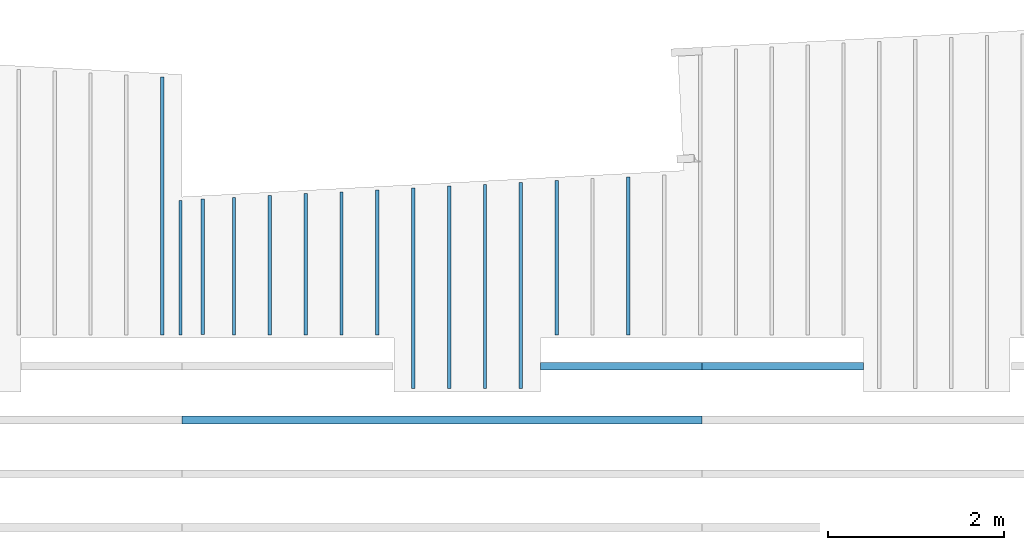
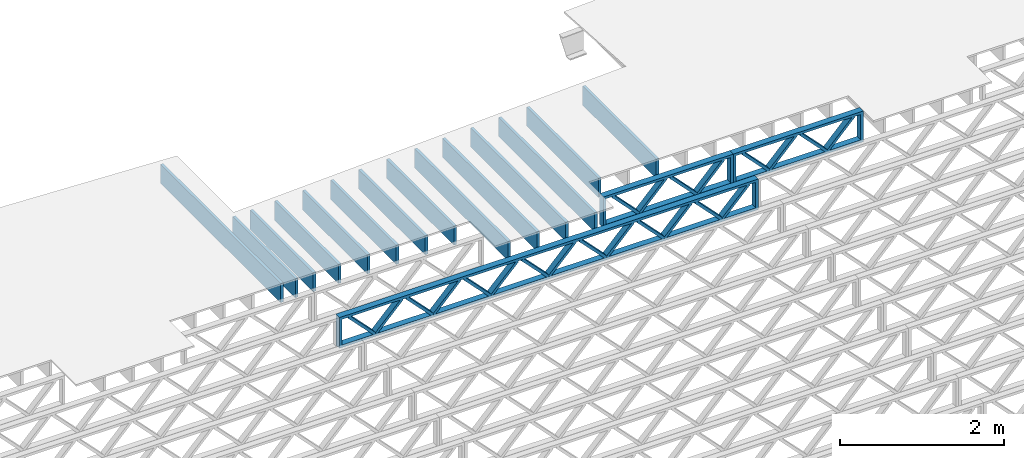
# One storey, part 5 of 13: 17 beams, 3 elements without a shape of their own.
"""IFC4 building model written with IfcOpenShell, lengths in feet."""

import ifcopenshell
import ifcopenshell.guid

model = None  # the IFC model being written
_history = None  # IfcOwnerHistory: only IFC2X3 demands one
_inside = {}  # id of a spatial element -> (the spatial element, [elements in it])
_under = {}  # id of a project, library or spatial element -> (it, [spatial elements below it])
_declared = {}  # id of a project -> (the project, [libraries it declares])
_typed = {}  # id of a type object -> (the type object, [elements of that type])
_made_of = {}  # id of a material, layer set ... -> (it, [elements and type objects made of it])


def new_model(schema):
    """Start an empty IFC model of exactly this schema.

    Asked for "IFC4X3", IfcOpenShell would pick the latest addendum, in which some entities
    have other attributes; the version numbers below select the first issue.
    IFC2X3 requires an IfcOwnerHistory on every rooted entity: one is made here for all.
    """
    global model, _history
    if schema == "IFC4X3":
        model = ifcopenshell.file(schema_version=(4, 3, 0, 0))
    else:
        model = ifcopenshell.file(schema=schema)
    _inside.clear()
    _under.clear()
    _declared.clear()
    _typed.clear()
    _made_of.clear()
    _history = None
    if model.schema == "IFC2X3":
        org = make("IfcOrganization", Name="unknown")
        user = make(
            "IfcPersonAndOrganization",
            ThePerson=make("IfcPerson", FamilyName="unknown"),
            TheOrganization=org,
        )
        app = make(
            "IfcApplication",
            ApplicationDeveloper=org,
            Version="unknown",
            ApplicationFullName="unknown",
            ApplicationIdentifier="unknown",
        )
        _history = make(
            "IfcOwnerHistory",
            OwningUser=user,
            OwningApplication=app,
            ChangeAction="ADDED",
            CreationDate=0,
        )
    return model


def make(cls, **values):
    """One entity of the class cls with the attributes given. An attribute that is None is left unset."""
    return model.create_entity(
        cls, **{name: value for name, value in values.items() if value is not None}
    )


def entity(cls, *values):
    """Any entity or typed value of the class cls, its attributes in the order of the schema. None: left unset."""
    e = model.create_entity(cls)
    for i, value in enumerate(values):
        if value is not None:
            e[i] = value
    return e


def rooted(cls, **values):
    """An entity with a GlobalId (a new one), such as an element, a storey or a relation."""
    return make(cls, GlobalId=ifcopenshell.guid.new(), OwnerHistory=_history, **values)


def si_unit(unit_type, name, prefix=None):
    """IfcSIUnit, for example si_unit("LENGTHUNIT", "METRE", prefix="MILLI")."""
    return make("IfcSIUnit", UnitType=unit_type, Prefix=prefix, Name=name)


def converted_unit(unit_type, name, factor, base, dimensions=None, offset=None):
    """IfcConversionBasedUnit, such as the inch: factor (a typed value) times the base unit."""
    return make(
        "IfcConversionBasedUnit"
        if offset is None
        else "IfcConversionBasedUnitWithOffset",
        ConversionOffset=offset,
        Dimensions=None
        if dimensions is None
        else entity("IfcDimensionalExponents", *dimensions),
        UnitType=unit_type,
        Name=name,
        ConversionFactor=make(
            "IfcMeasureWithUnit", ValueComponent=factor, UnitComponent=base
        ),
    )


def derived_unit(unit_type, elements):
    """IfcDerivedUnit: a product of units, each with its exponent."""
    return make(
        "IfcDerivedUnit",
        Elements=[
            make("IfcDerivedUnitElement", Unit=unit, Exponent=power)
            for unit, power in elements
        ],
        UnitType=unit_type,
    )


def assignment(units):
    """IfcUnitAssignment: the units of a project."""
    return None if units is None else make("IfcUnitAssignment", Units=units)


def point(xyz):
    """IfcCartesianPoint."""
    return None if xyz is None else make("IfcCartesianPoint", Coordinates=xyz)


def direction(xyz):
    """IfcDirection."""
    return None if xyz is None else make("IfcDirection", DirectionRatios=xyz)


def frame(location, z_axis=None, x_axis=None):
    """IfcAxis2Placement3D, a coordinate frame: its origin and axes. An axis left out is left unset."""
    return make(
        "IfcAxis2Placement3D",
        Location=point(location),
        Axis=direction(z_axis),
        RefDirection=direction(x_axis),
    )


def frame_2d(location, x_axis=None):
    """IfcAxis2Placement2D, a coordinate frame in the plane: its origin and x axis."""
    return make(
        "IfcAxis2Placement2D", Location=point(location), RefDirection=direction(x_axis)
    )


def origin():
    """The frame at (0, 0, 0) with its axes left unset."""
    return frame((0.0, 0.0, 0.0))


def origin_2d_with_axis():
    """The frame at (0, 0) in the plane with the x axis (1, 0) written out."""
    return frame_2d((0.0, 0.0), x_axis=(1.0, 0.0))


def place(relative_to, where):
    """IfcLocalPlacement: puts the frame where relative to a parent placement (None: the world)."""
    return make(
        "IfcLocalPlacement", PlacementRelTo=relative_to, RelativePlacement=where
    )


def context(
    kind, dimensions, precision=None, world=None, true_north=None, identifier=None
):
    """IfcGeometricRepresentationContext, for example the 3D "Model" context."""
    return make(
        "IfcGeometricRepresentationContext",
        ContextIdentifier=identifier,
        ContextType=kind,
        CoordinateSpaceDimension=dimensions,
        Precision=precision,
        WorldCoordinateSystem=world,
        TrueNorth=true_north,
    )


def subcontext(parent, identifier, kind, view, scale=None):
    """IfcGeometricRepresentationSubContext, for example "Body" below "Model"."""
    return make(
        "IfcGeometricRepresentationSubContext",
        ContextIdentifier=identifier,
        ContextType=kind,
        ParentContext=parent,
        TargetScale=scale,
        TargetView=view,
    )


def project(units=None, contexts=None):
    """IfcProject with its units and contexts."""
    return rooted(
        "IfcProject",
        Name="project",
        RepresentationContexts=contexts,
        UnitsInContext=assignment(units),
    )


def spatial(cls, under=None, at=None, **own):
    """A site, building, storey or space (cls), placed at a placement, below another one or the project."""
    s = rooted(cls, ObjectPlacement=at, **own)
    if under is not None:
        _under.setdefault(under.id(), (under, []))[1].append(s)
    return s


def profile(cls, at=None, kind="AREA", **sizes):
    """A parametric profile (cls). Its sizes go by their IFC names, for example OverallWidth=200.0."""
    return make(cls, ProfileType=kind, Position=at, **sizes)


def rectangle(**sizes):
    """IfcRectangleProfileDef."""
    return profile("IfcRectangleProfileDef", **sizes)


def extrude(swept, where, along, depth):
    """IfcExtrudedAreaSolid: the profile swept, set in the frame where, extruded along a direction by depth."""
    return make(
        "IfcExtrudedAreaSolid",
        SweptArea=swept,
        Position=where,
        ExtrudedDirection=direction(along),
        Depth=depth,
    )


def shape(context_of_items, identifier, shape_type, items):
    """IfcShapeRepresentation: the items that make up one representation, for example the "Body"."""
    return make(
        "IfcShapeRepresentation",
        ContextOfItems=context_of_items,
        RepresentationIdentifier=identifier,
        RepresentationType=shape_type,
        Items=items,
    )


def source(mapping_origin, context_of_items, identifier, shape_type, items):
    """IfcRepresentationMap: a shape defined once, which mapped items show again and again."""
    return make(
        "IfcRepresentationMap",
        MappingOrigin=mapping_origin,
        MappedRepresentation=shape(context_of_items, identifier, shape_type, items),
    )


def transform(
    local_origin,
    x_axis=None,
    y_axis=None,
    z_axis=None,
    scale=None,
    scale2=None,
    scale3=None,
    uniform=True,
):
    """IfcCartesianTransformationOperator3D, or its non-uniform kind. x_axis, y_axis, z_axis: its Axis1, 2, 3."""
    if uniform:
        return make(
            "IfcCartesianTransformationOperator3D",
            Axis1=direction(x_axis),
            Axis2=direction(y_axis),
            LocalOrigin=point(local_origin),
            Scale=scale,
            Axis3=direction(z_axis),
        )
    return make(
        "IfcCartesianTransformationOperator3DnonUniform",
        Axis1=direction(x_axis),
        Axis2=direction(y_axis),
        LocalOrigin=point(local_origin),
        Scale=scale,
        Axis3=direction(z_axis),
        Scale2=scale2,
        Scale3=scale3,
    )


def mapped(mapping_source, mapping_target):
    """IfcMappedItem: shows the shape of a source again, moved by a transform."""
    return make(
        "IfcMappedItem", MappingSource=mapping_source, MappingTarget=mapping_target
    )


def material(Name=None, Category=None):
    """IfcMaterial."""
    return make("IfcMaterial", Name=Name, Category=Category)


def material_profile(
    of_material, cross_section, Name=None, Category=None, Priority=None
):
    """IfcMaterialProfile: a cross section and its material."""
    return make(
        "IfcMaterialProfile",
        Name=Name,
        Material=of_material,
        Profile=cross_section,
        Priority=Priority,
        Category=Category,
    )


def profile_set(profiles, Name=None, composite=None):
    """IfcMaterialProfileSet."""
    return make(
        "IfcMaterialProfileSet",
        Name=Name,
        MaterialProfiles=profiles,
        CompositeProfile=composite,
    )


def profile_usage(for_profile_set, cardinal=None, extent=None):
    """IfcMaterialProfileSetUsage: how a profile set lies along its element."""
    return make(
        "IfcMaterialProfileSetUsage",
        ForProfileSet=for_profile_set,
        CardinalPoint=cardinal,
        ReferenceExtent=extent,
    )


def made_of(thing, what):
    """Note that an element or type object is made of a material, layer set ...; save() writes the relation."""
    if what is not None:
        _made_of.setdefault(what.id(), (what, []))[1].append(thing)
    return thing


def type_object(cls, material=None, **own):
    """A type object (cls), such as IfcWallType, which elements share."""
    return made_of(rooted(cls, **own), material)


def type_shapes(of_type, sources):
    """Give a type object the sources (RepresentationMaps) that its elements show as mapped items."""
    of_type.RepresentationMaps = sources


def element(
    cls,
    number,
    at=None,
    inside=None,
    cuts=None,
    type_object=None,
    material=None,
    context=None,
    identifier="Body",
    shape_type=None,
    held_by="IfcProductDefinitionShape",
    body=None,
    shapes=None,
    **own,
):
    """One element of the class cls, such as IfcWall. Its Tag is "e" and its number.

    at: its placement. inside: the storey or other place that contains it. cuts: it is an
    opening in that element (IfcRelVoidsElement). A single representation is given by context,
    identifier, shape_type and body (its items); several are given by shapes. held_by: the class
    of the entity that holds the representations. save() writes the other relations.
    """
    e = rooted(cls, Tag="e%d" % number, ObjectPlacement=at, **own)
    if body is not None:
        shapes = [shape(context, identifier, shape_type, body)]
    if shapes is not None:
        e.Representation = make(held_by, Representations=shapes)
    if inside is not None:
        _inside.setdefault(inside.id(), (inside, []))[1].append(e)
    if cuts is not None:
        rooted(
            "IfcRelVoidsElement", RelatingBuildingElement=cuts, RelatedOpeningElement=e
        )
    if type_object is not None:
        _typed.setdefault(type_object.id(), (type_object, []))[1].append(e)
    return made_of(e, material)


def aggregate(whole, parts):
    """IfcRelAggregates: a whole, such as a stair, and the parts it consists of."""
    return rooted("IfcRelAggregates", RelatingObject=whole, RelatedObjects=parts)


def save(model, path):
    """Write the relations noted so far, then the file.

    IfcRelAggregates (storeys below a building ...), IfcRelContainedInSpatialStructure (elements
    in a storey), IfcRelDefinesByType, IfcRelAssociatesMaterial and IfcRelDeclares: one each for
    every whole, place, type object, material and project.
    """
    for whole, parts in _under.values():
        aggregate(whole, parts)
    for where, things in _inside.values():
        rooted(
            "IfcRelContainedInSpatialStructure",
            RelatedElements=things,
            RelatingStructure=where,
        )
    for kind, things in _typed.values():
        rooted("IfcRelDefinesByType", RelatedObjects=things, RelatingType=kind)
    for what, things in _made_of.values():
        rooted("IfcRelAssociatesMaterial", RelatedObjects=things, RelatingMaterial=what)
    for by, libraries in _declared.values():
        rooted("IfcRelDeclares", RelatingContext=by, RelatedDefinitions=libraries)
    model.write(path)


model = new_model("IFC4")

# Units and contexts
model_context_1 = context("Model", 3, precision=0.0001, world=origin(), true_north=direction((6.12303176911189e-17, 1.0)))
model_context_2 = context("Model", 3, precision=0.0001, world=origin(), true_north=direction((6.12303176911189e-17, 1.0)))
body_context = subcontext(model_context_2, "Body", "Model", "MODEL_VIEW")
ifc_project = project(units=[converted_unit("LENGTHUNIT", "FOOT", entity("IfcRatioMeasure", 0.3048), si_unit("LENGTHUNIT", "METRE"), dimensions=[1, 0, 0, 0, 0, 0, 0]), converted_unit("AREAUNIT", "SQUARE FOOT", entity("IfcRatioMeasure", 0.09290304), si_unit("AREAUNIT", "SQUARE_METRE"), dimensions=[2, 0, 0, 0, 0, 0, 0]), converted_unit("VOLUMEUNIT", "CUBIC FOOT", entity("IfcRatioMeasure", 0.028316846592), si_unit("VOLUMEUNIT", "CUBIC_METRE"), dimensions=[3, 0, 0, 0, 0, 0, 0]), converted_unit("PLANEANGLEUNIT", "DEGREE", entity("IfcRatioMeasure", 0.0174532925199433), si_unit("PLANEANGLEUNIT", "RADIAN"), dimensions=[0, 0, 0, 0, 0, 0, 0]), si_unit("MASSUNIT", "GRAM", prefix="KILO"), derived_unit("MASSDENSITYUNIT", [(si_unit("MASSUNIT", "GRAM", prefix="KILO"), 1), (si_unit("LENGTHUNIT", "METRE"), -3)]), derived_unit("MOMENTOFINERTIAUNIT", [(si_unit("LENGTHUNIT", "METRE"), 4)]), si_unit("TIMEUNIT", "SECOND"), si_unit("FREQUENCYUNIT", "HERTZ"), si_unit("THERMODYNAMICTEMPERATUREUNIT", "DEGREE_CELSIUS"), derived_unit("THERMALTRANSMITTANCEUNIT", [(si_unit("MASSUNIT", "GRAM", prefix="KILO"), 1), (si_unit("THERMODYNAMICTEMPERATUREUNIT", "KELVIN"), -1), (si_unit("TIMEUNIT", "SECOND"), -3)]), derived_unit("VOLUMETRICFLOWRATEUNIT", [(si_unit("LENGTHUNIT", "METRE"), 3), (si_unit("TIMEUNIT", "SECOND"), -1)]), si_unit("ELECTRICCURRENTUNIT", "AMPERE"), si_unit("ELECTRICVOLTAGEUNIT", "VOLT"), si_unit("POWERUNIT", "WATT"), si_unit("FORCEUNIT", "NEWTON"), si_unit("ILLUMINANCEUNIT", "LUX"), si_unit("LUMINOUSFLUXUNIT", "LUMEN"), si_unit("LUMINOUSINTENSITYUNIT", "CANDELA"), derived_unit("USERDEFINED", [(si_unit("MASSUNIT", "GRAM", prefix="KILO"), -1), (si_unit("LENGTHUNIT", "METRE"), -2), (si_unit("TIMEUNIT", "SECOND"), 3), (si_unit("LUMINOUSFLUXUNIT", "LUMEN"), 1)]), derived_unit("LINEARVELOCITYUNIT", [(si_unit("LENGTHUNIT", "METRE"), 1), (si_unit("TIMEUNIT", "SECOND"), -1)]), si_unit("PRESSUREUNIT", "PASCAL"), derived_unit("USERDEFINED", [(si_unit("LENGTHUNIT", "METRE"), -2), (si_unit("MASSUNIT", "GRAM", prefix="KILO"), 1), (si_unit("TIMEUNIT", "SECOND"), -2)]), derived_unit("LINEARFORCEUNIT", [(si_unit("MASSUNIT", "GRAM", prefix="KILO"), 1), (si_unit("LENGTHUNIT", "METRE"), 1), (si_unit("TIMEUNIT", "SECOND"), -2), (si_unit("LENGTHUNIT", "METRE"), -1)]), derived_unit("PLANARFORCEUNIT", [(si_unit("MASSUNIT", "GRAM", prefix="KILO"), 1), (si_unit("LENGTHUNIT", "METRE"), 1), (si_unit("TIMEUNIT", "SECOND"), -2), (si_unit("LENGTHUNIT", "METRE"), -2)])], contexts=[model_context_1])

# Site, building, storey
site_placement = place(None, origin())
site = spatial("IfcSite", under=ifc_project, at=site_placement, CompositionType="ELEMENT")
building_placement = place(site_placement, origin())
building = spatial("IfcBuilding", under=site, at=building_placement, CompositionType="ELEMENT")
storey_placement = place(building_placement, frame((0.0, 0.0, 21.46875)))
storey = spatial("IfcBuildingStorey", under=building, at=storey_placement, Name="3RD FLOOR", CompositionType="ELEMENT", Elevation=21.46875)

# Assembly, beam
assembly_1_placement = place(storey_placement, origin())
assembly_1 = element("IfcElementAssembly", 1, at=assembly_1_placement, inside=storey, Name="Structural Beam System:Structural Framing System", ObjectType="Structural Beam System:Structural Framing System", AssemblyPlace="NOTDEFINED", PredefinedType="BEAM_GRID")
ifc_material_1 = material(Name="WOOD TRUSS", Category="Materials")
ifc_material_profile_1 = material_profile(ifc_material_1, rectangle(XDim=1.73473973950632, YDim=0.125, at=frame_2d((-1.11022302462516e-16, 8.32667268468867e-17), x_axis=(1.0, 0.0))))
ifc_material_profile_2 = material_profile(ifc_material_1, rectangle(XDim=1.73473973950633, YDim=0.125, at=frame_2d((-1.11022302462516e-16, 8.32667268468867e-17), x_axis=(1.0, 0.0))))
ifc_material_profile_3 = material_profile(ifc_material_1, rectangle(XDim=1.73473973950632, YDim=0.125, at=frame_2d((-5.55111512312578e-17, 1.38777878078145e-16), x_axis=(1.0, 0.0))))
ifc_material_profile_4 = material_profile(ifc_material_1, rectangle(XDim=1.73473973950633, YDim=0.125, at=frame_2d((-1.11022302462516e-16, 8.32667268468867e-17), x_axis=(1.0, 0.0))))
ifc_material_profile_5 = material_profile(ifc_material_1, rectangle(XDim=1.73473973950632, YDim=0.125, at=frame_2d((-1.11022302462516e-16, 8.32667268468867e-17), x_axis=(1.0, 0.0))))
ifc_material_profile_6 = material_profile(ifc_material_1, rectangle(XDim=1.73473973950633, YDim=0.125, at=frame_2d((-2.77555756156289e-16, 3.05311331771918e-16), x_axis=(1.0, 0.0))))
ifc_material_profile_7 = material_profile(ifc_material_1, rectangle(XDim=1.73473973950632, YDim=0.124999999999999, at=frame_2d((-3.88578058618805e-16, -2.4980018054066e-16), x_axis=(1.0, 0.0))))
ifc_material_profile_8 = material_profile(ifc_material_1, rectangle(XDim=1.73473973950633, YDim=0.125, at=frame_2d((2.77555756156289e-16, -3.05311331771918e-16), x_axis=(1.0, 0.0))))
ifc_material_profile_9 = material_profile(ifc_material_1, rectangle(XDim=1.73473973950632, YDim=0.124999999999999, at=frame_2d((-1.11022302462516e-16, 8.32667268468867e-17), x_axis=(1.0, 0.0))))
ifc_material_profile_10 = material_profile(ifc_material_1, rectangle(XDim=1.73473973950633, YDim=0.125, at=origin_2d_with_axis()))
ifc_material_profile_11 = material_profile(ifc_material_1, rectangle(XDim=0.124999999999982, YDim=0.291666666666668, at=origin_2d_with_axis()))
ifc_material_profile_12 = material_profile(ifc_material_1, rectangle(XDim=0.124999999999932, YDim=0.291666666666664, at=origin_2d_with_axis()))
ifc_material_profile_13 = material_profile(ifc_material_1, rectangle(XDim=1.25000000000002, YDim=0.29166666666667, at=origin_2d_with_axis()))
ifc_material_profile_14 = material_profile(ifc_material_1, rectangle(XDim=1.25000000000004, YDim=0.291666666666667, at=origin_2d_with_axis()))
ifc_profile_set_1 = profile_set([ifc_material_profile_1, ifc_material_profile_2, ifc_material_profile_3, ifc_material_profile_4, ifc_material_profile_5, ifc_material_profile_6, ifc_material_profile_7, ifc_material_profile_8, ifc_material_profile_9, ifc_material_profile_10, ifc_material_profile_11, ifc_material_profile_12, ifc_material_profile_13, ifc_material_profile_14])
ifc_profile_usage_1 = profile_usage(ifc_profile_set_1, cardinal=8)
beam_type_1 = type_object("IfcBeamType", PredefinedType="BEAM", material=ifc_profile_set_1)
shared_shape_1 = source(origin(), body_context, "Body", "SweptSolid", [
    extrude(rectangle(XDim=1.73473973950632, YDim=0.125, at=frame_2d((0.0, 1.66533453693773e-16), x_axis=(1.0, 0.0))), frame((1.95847610985504, -0.145833333333334, 0.0), z_axis=(0.0, 1.0, 0.0), x_axis=(0.693383046997606, 0.0, 0.720569184836762)), (0.0, 0.0, 1.0), 0.291666666666667),
    extrude(rectangle(XDim=1.73473973950633, YDim=0.125, at=frame_2d((-5.55111512312578e-17, 8.32667268468867e-17), x_axis=(1.0, 0.0))), frame((0.708190236181772, -0.145833333333334, 0.0), z_axis=(0.0, 1.0, 0.0), x_axis=(0.69338304699761, 0.0, -0.720569184836758)), (0.0, 0.0, 1.0), 0.291666666666667),
    extrude(rectangle(XDim=1.73473973950632, YDim=0.125, at=frame_2d((0.0, 1.66533453693773e-16), x_axis=(1.0, 0.0))), frame((-0.708190236181118, -0.145833333333334, 0.0), z_axis=(0.0, 1.0, 0.0), x_axis=(0.693383046997606, 0.0, 0.720569184836762)), (0.0, 0.0, 1.0), 0.291666666666667),
    extrude(rectangle(XDim=1.73473973950633, YDim=0.125, at=frame_2d((-2.22044604925031e-16, 2.22044604925031e-16), x_axis=(1.0, 0.0))), frame((-1.95847610985439, -0.145833333333334, 0.0), z_axis=(0.0, 1.0, 0.0), x_axis=(0.69338304699761, 0.0, -0.720569184836758)), (0.0, 0.0, 1.0), 0.291666666666666),
    extrude(rectangle(XDim=0.124999999999982, YDim=0.291666666666668, at=origin_2d_with_axis()), frame((-2.99999983968466, 0.0, 0.687500000000054), z_axis=(1.0, 0.0, 0.0), x_axis=(0.0, 0.0, -1.0)), (0.0, 0.0, 1.0), 5.99999967936932),
    extrude(rectangle(XDim=0.124999999999932, YDim=0.291666666666664, at=origin_2d_with_axis()), frame((-2.99999983968445, 0.0, -0.687499999999984), z_axis=(1.0, 0.0, 0.0), x_axis=(0.0, 0.0, -1.0)), (0.0, 0.0, 1.0), 5.99999967936911),
    extrude(rectangle(XDim=1.25000000000002, YDim=0.29166666666667, at=origin_2d_with_axis()), frame((2.87499983968464, 0.0, 0.0), z_axis=(1.0, 0.0, 0.0), x_axis=(0.0, 0.0, -1.0)), (0.0, 0.0, 1.0), 0.12500000000002),
    extrude(rectangle(XDim=1.25000000000004, YDim=0.291666666666667, at=origin_2d_with_axis()), frame((-2.99999983968466, 0.0, 0.0), z_axis=(1.0, 0.0, 0.0), x_axis=(0.0, 0.0, -1.0)), (0.0, 0.0, 1.0), 0.125000000000023),
])
type_shapes(beam_type_1, [shared_shape_1])
beam_1_placement = place(assembly_1_placement, frame((-219.404827312476, 957.861934882651, -0.947916666666874), z_axis=(0.0, 0.0, 1.0), x_axis=(-1.0, 0.0, 0.0)))
beam_1 = element("IfcBeam", 2, at=beam_1_placement, type_object=beam_type_1, material=ifc_profile_usage_1, PredefinedType="BEAM", context=body_context, shape_type="MappedRepresentation", body=[
    mapped(shared_shape_1, transform((0.0, 0.0, 0.0), scale=1.0)),
])
aggregate(assembly_1, [beam_1])

# Beam
ifc_material_2 = material(Category="Materials")
ifc_material_profile_15 = material_profile(ifc_material_2, rectangle(XDim=0.9375, YDim=0.125000000000011, at=origin_2d_with_axis()))
ifc_profile_set_2 = profile_set([ifc_material_profile_15])
ifc_profile_usage_2 = profile_usage(ifc_profile_set_2, cardinal=8)
beam_type_2 = type_object("IfcBeamType", PredefinedType="BEAM", material=ifc_profile_set_2)
shared_shape_2 = source(origin(), body_context, "Body", "SweptSolid", [
    extrude(rectangle(XDim=0.9375, YDim=0.125000000000011, at=origin_2d_with_axis()), frame((-2.50173504911743, 0.0, 0.0), z_axis=(1.0, 0.0, 0.0), x_axis=(0.0, 0.0, -1.0)), (0.0, 0.0, 1.0), 5.00347009823486),
])
type_shapes(beam_type_2, [shared_shape_2])
beam_2_placement = place(storey_placement, frame((-241.800660485556, 961.531253902547, -0.729166666666714), z_axis=(0.0, 0.0, 1.0), x_axis=(0.0, 1.0, 0.0)))
element("IfcBeam", 3, at=beam_2_placement, inside=storey, type_object=beam_type_2, material=ifc_profile_usage_2, PredefinedType="BEAM", context=body_context, shape_type="MappedRepresentation", body=[
    mapped(shared_shape_2, transform((0.0, 0.0, 0.0), scale=1.0)),
])

# Assembly, beams
assembly_2_placement = place(storey_placement, origin())
assembly_2 = element("IfcElementAssembly", 4, at=assembly_2_placement, inside=storey, Name="Structural Beam System:Structural Framing System", ObjectType="Structural Beam System:Structural Framing System", AssemblyPlace="NOTDEFINED", PredefinedType="BEAM_GRID")
ifc_profile_usage_3 = profile_usage(ifc_profile_set_2, cardinal=8)
beam_type_3 = type_object("IfcBeamType", PredefinedType="BEAM", material=ifc_profile_set_2)
shared_shape_3 = source(origin(), body_context, "Body", "SweptSolid", [
    extrude(rectangle(XDim=0.9375, YDim=0.125000000000011, at=origin_2d_with_axis()), frame((-2.93819683267299, 0.0, 0.0), z_axis=(1.0, 0.0, 0.0), x_axis=(0.0, 0.0, -1.0)), (0.0, 0.0, 1.0), 5.87639366534597),
])
type_shapes(beam_type_3, [shared_shape_3])
beam_3_placement = place(assembly_2_placement, frame((-225.144289395965, 961.967715694021, -0.729166666666714), z_axis=(0.0, 0.0, 1.0), x_axis=(0.0, 1.0, 0.0)))
beam_3 = element("IfcBeam", 5, at=beam_3_placement, type_object=beam_type_3, material=ifc_profile_usage_3, PredefinedType="BEAM", context=body_context, shape_type="MappedRepresentation", body=[
    mapped(shared_shape_3, transform((0.0, 0.0, 0.0), scale=1.0)),
])
ifc_profile_usage_4 = profile_usage(ifc_profile_set_2, cardinal=8)
beam_type_4 = type_object("IfcBeamType", PredefinedType="BEAM", material=ifc_profile_set_2)
shared_shape_4 = source(origin(), body_context, "Body", "SweptSolid", [
    extrude(rectangle(XDim=0.9375, YDim=0.125000000000011, at=origin_2d_with_axis()), frame((-3.83338259433134, 0.0, 0.0), z_axis=(1.0, 0.0, 0.0), x_axis=(0.0, 0.0, -1.0)), (0.0, 0.0, 1.0), 7.66676518866268),
])
type_shapes(beam_type_4, [shared_shape_4])
beam_4_placement = place(assembly_2_placement, frame((-229.144289395965, 960.862898815231, -0.729166666666714), z_axis=(0.0, 0.0, 1.0), x_axis=(0.0, 1.0, 0.0)))
beam_4 = element("IfcBeam", 6, at=beam_4_placement, type_object=beam_type_4, material=ifc_profile_usage_4, PredefinedType="BEAM", context=body_context, shape_type="MappedRepresentation", body=[
    mapped(shared_shape_4, transform((0.0, 0.0, 0.0), scale=1.0)),
])
ifc_profile_usage_5 = profile_usage(ifc_profile_set_2, cardinal=8)
beam_type_5 = type_object("IfcBeamType", PredefinedType="BEAM", material=ifc_profile_set_2)
shared_shape_5 = source(origin(), body_context, "Body", "SweptSolid", [
    extrude(rectangle(XDim=0.9375, YDim=0.125000000000011, at=origin_2d_with_axis()), frame((-3.79844407480942, 0.0, 0.0), z_axis=(1.0, 0.0, 0.0), x_axis=(0.0, 0.0, -1.0)), (0.0, 0.0, 1.0), 7.59688814961885),
])
type_shapes(beam_type_5, [shared_shape_5])
beam_5_placement = place(assembly_2_placement, frame((-230.477622729298, 960.827960295709, -0.729166666666714), z_axis=(0.0, 0.0, 1.0), x_axis=(0.0, 1.0, 0.0)))
beam_5 = element("IfcBeam", 7, at=beam_5_placement, type_object=beam_type_5, material=ifc_profile_usage_5, PredefinedType="BEAM", context=body_context, shape_type="MappedRepresentation", body=[
    mapped(shared_shape_5, transform((0.0, 0.0, 0.0), scale=1.0)),
])
ifc_profile_usage_6 = profile_usage(ifc_profile_set_2, cardinal=8)
beam_type_6 = type_object("IfcBeamType", PredefinedType="BEAM", material=ifc_profile_set_2)
shared_shape_6 = source(origin(), body_context, "Body", "SweptSolid", [
    extrude(rectangle(XDim=0.9375, YDim=0.125000000000011, at=origin_2d_with_axis()), frame((-2.65868951796261, 0.0, 0.0), z_axis=(1.0, 0.0, 0.0), x_axis=(0.0, 0.0, -1.0)), (0.0, 0.0, 1.0), 5.31737903592523),
])
type_shapes(beam_type_6, [shared_shape_6])
beam_6_placement = place(assembly_2_placement, frame((-235.810956062631, 961.68820669638, -0.729166666666714), z_axis=(0.0, 0.0, 1.0), x_axis=(0.0, 1.0, 0.0)))
beam_6 = element("IfcBeam", 8, at=beam_6_placement, type_object=beam_type_6, material=ifc_profile_usage_6, PredefinedType="BEAM", context=body_context, shape_type="MappedRepresentation", body=[
    mapped(shared_shape_6, transform((0.0, 0.0, 0.0), scale=1.0)),
])
ifc_profile_usage_7 = profile_usage(ifc_profile_set_2, cardinal=8)
beam_type_7 = type_object("IfcBeamType", PredefinedType="BEAM", material=ifc_profile_set_2)
shared_shape_7 = source(origin(), body_context, "Body", "SweptSolid", [
    extrude(rectangle(XDim=0.9375, YDim=0.125000000000011, at=origin_2d_with_axis()), frame((-2.62375083093946, 0.0, 0.0), z_axis=(1.0, 0.0, 0.0), x_axis=(0.0, 0.0, -1.0)), (0.0, 0.0, 1.0), 5.24750166187891),
])
type_shapes(beam_type_7, [shared_shape_7])
beam_7_placement = place(assembly_2_placement, frame((-237.144289395965, 961.653268344359, -0.729166666666714), z_axis=(0.0, 0.0, 1.0), x_axis=(0.0, 1.0, 0.0)))
beam_7 = element("IfcBeam", 9, at=beam_7_placement, type_object=beam_type_7, material=ifc_profile_usage_7, PredefinedType="BEAM", context=body_context, shape_type="MappedRepresentation", body=[
    mapped(shared_shape_7, transform((0.0, 0.0, 0.0), scale=1.0)),
])
ifc_profile_usage_8 = profile_usage(ifc_profile_set_2, cardinal=8)
beam_type_8 = type_object("IfcBeamType", PredefinedType="BEAM", material=ifc_profile_set_2)
shared_shape_8 = source(origin(), body_context, "Body", "SweptSolid", [
    extrude(rectangle(XDim=0.9375, YDim=0.125000000000011, at=origin_2d_with_axis()), frame((-4.79624042361354, 0.0, 0.0), z_axis=(1.0, 0.0, 0.0), x_axis=(0.0, 0.0, -1.0)), (0.0, 0.0, 1.0), 9.59248084722708),
])
type_shapes(beam_type_8, [shared_shape_8])
beam_8_placement = place(assembly_2_placement, frame((-242.477622729298, 963.825759277043, -0.729166666666714), z_axis=(0.0, 0.0, 1.0), x_axis=(0.0, 1.0, 0.0)))
beam_8 = element("IfcBeam", 10, at=beam_8_placement, type_object=beam_type_8, material=ifc_profile_usage_8, PredefinedType="BEAM", context=body_context, shape_type="MappedRepresentation", body=[
    mapped(shared_shape_8, transform((0.0, 0.0, 0.0), scale=1.0)),
])
ifc_profile_usage_9 = profile_usage(ifc_profile_set_2, cardinal=8)
beam_type_9 = type_object("IfcBeamType", PredefinedType="BEAM", material=ifc_profile_set_2)
shared_shape_9 = source(origin(), body_context, "Body", "SweptSolid", [
    extrude(rectangle(XDim=0.9375, YDim=0.125000000000011, at=origin_2d_with_axis()), frame((-2.55387345689314, 0.0, 0.0), z_axis=(1.0, 0.0, 0.0), x_axis=(0.0, 0.0, -1.0)), (0.0, 0.0, 1.0), 5.10774691378629),
])
type_shapes(beam_type_9, [shared_shape_9])
beam_9_placement = place(assembly_2_placement, frame((-239.810956062631, 961.583391640318, -0.729166666666714), z_axis=(0.0, 0.0, 1.0), x_axis=(0.0, 1.0, 0.0)))
beam_9 = element("IfcBeam", 11, at=beam_9_placement, type_object=beam_type_9, material=ifc_profile_usage_9, PredefinedType="BEAM", context=body_context, shape_type="MappedRepresentation", body=[
    mapped(shared_shape_9, transform((0.0, 0.0, 0.0), scale=1.0)),
])
ifc_profile_usage_10 = profile_usage(ifc_profile_set_2, cardinal=8)
beam_type_10 = type_object("IfcBeamType", PredefinedType="BEAM", material=ifc_profile_set_2)
shared_shape_10 = source(origin(), body_context, "Body", "SweptSolid", [
    extrude(rectangle(XDim=0.9375, YDim=0.125000000000011, at=origin_2d_with_axis()), frame((-2.58881214391624, 0.0, 0.0), z_axis=(1.0, 0.0, 0.0), x_axis=(0.0, 0.0, -1.0)), (0.0, 0.0, 1.0), 5.17762428783249),
])
type_shapes(beam_type_10, [shared_shape_10])
beam_10_placement = place(assembly_2_placement, frame((-238.477622729298, 961.618329992338, -0.729166666666714), z_axis=(0.0, 0.0, 1.0), x_axis=(0.0, 1.0, 0.0)))
beam_10 = element("IfcBeam", 12, at=beam_10_placement, type_object=beam_type_10, material=ifc_profile_usage_10, PredefinedType="BEAM", context=body_context, shape_type="MappedRepresentation", body=[
    mapped(shared_shape_10, transform((0.0, 0.0, 0.0), scale=1.0)),
])
ifc_profile_usage_11 = profile_usage(ifc_profile_set_2, cardinal=8)
beam_type_11 = type_object("IfcBeamType", PredefinedType="BEAM", material=ifc_profile_set_2)
shared_shape_11 = source(origin(), body_context, "Body", "SweptSolid", [
    extrude(rectangle(XDim=0.9375, YDim=0.125000000000011, at=origin_2d_with_axis()), frame((-2.69362820498583, 0.0, 0.0), z_axis=(1.0, 0.0, 0.0), x_axis=(0.0, 0.0, -1.0)), (0.0, 0.0, 1.0), 5.38725640997166),
])
type_shapes(beam_type_11, [shared_shape_11])
beam_11_placement = place(assembly_2_placement, frame((-234.477622729298, 961.723145048401, -0.729166666666714), z_axis=(0.0, 0.0, 1.0), x_axis=(0.0, 1.0, 0.0)))
beam_11 = element("IfcBeam", 13, at=beam_11_placement, type_object=beam_type_11, material=ifc_profile_usage_11, PredefinedType="BEAM", context=body_context, shape_type="MappedRepresentation", body=[
    mapped(shared_shape_11, transform((0.0, 0.0, 0.0), scale=1.0)),
])
ifc_profile_usage_12 = profile_usage(ifc_profile_set_2, cardinal=8)
beam_type_12 = type_object("IfcBeamType", PredefinedType="BEAM", material=ifc_profile_set_2)
shared_shape_12 = source(origin(), body_context, "Body", "SweptSolid", [
    extrude(rectangle(XDim=0.9375, YDim=0.125000000000011, at=origin_2d_with_axis()), frame((-3.72856703576554, 0.0, 0.0), z_axis=(1.0, 0.0, 0.0), x_axis=(0.0, 0.0, -1.0)), (0.0, 0.0, 1.0), 7.45713407153107),
])
type_shapes(beam_type_12, [shared_shape_12])
beam_12_placement = place(assembly_2_placement, frame((-233.144289395965, 960.758083256665, -0.729166666666714), z_axis=(0.0, 0.0, 1.0), x_axis=(0.0, 1.0, 0.0)))
beam_12 = element("IfcBeam", 14, at=beam_12_placement, type_object=beam_type_12, material=ifc_profile_usage_12, PredefinedType="BEAM", context=body_context, shape_type="MappedRepresentation", body=[
    mapped(shared_shape_12, transform((0.0, 0.0, 0.0), scale=1.0)),
])
ifc_profile_usage_13 = profile_usage(ifc_profile_set_2, cardinal=8)
beam_type_13 = type_object("IfcBeamType", PredefinedType="BEAM", material=ifc_profile_set_2)
shared_shape_13 = source(origin(), body_context, "Body", "SweptSolid", [
    extrude(rectangle(XDim=0.9375, YDim=0.125000000000011, at=origin_2d_with_axis()), frame((-3.76350555528745, 0.0, 0.0), z_axis=(1.0, 0.0, 0.0), x_axis=(0.0, 0.0, -1.0)), (0.0, 0.0, 1.0), 7.5270111105749),
])
type_shapes(beam_type_13, [shared_shape_13])
beam_13_placement = place(assembly_2_placement, frame((-231.810956062631, 960.793021776187, -0.729166666666714), z_axis=(0.0, 0.0, 1.0), x_axis=(0.0, 1.0, 0.0)))
beam_13 = element("IfcBeam", 15, at=beam_13_placement, type_object=beam_type_13, material=ifc_profile_usage_13, PredefinedType="BEAM", context=body_context, shape_type="MappedRepresentation", body=[
    mapped(shared_shape_13, transform((0.0, 0.0, 0.0), scale=1.0)),
])
ifc_profile_usage_14 = profile_usage(ifc_profile_set_2, cardinal=8)
beam_type_14 = type_object("IfcBeamType", PredefinedType="BEAM", material=ifc_profile_set_2)
shared_shape_14 = source(origin(), body_context, "Body", "SweptSolid", [
    extrude(rectangle(XDim=0.9375, YDim=0.125000000000011, at=origin_2d_with_axis()), frame((-2.86831945862667, 0.0, 0.0), z_axis=(1.0, 0.0, 0.0), x_axis=(0.0, 0.0, -1.0)), (0.0, 0.0, 1.0), 5.73663891725334),
])
type_shapes(beam_type_14, [shared_shape_14])
beam_14_placement = place(assembly_2_placement, frame((-227.810956062631, 961.897838989979, -0.729166666666714), z_axis=(0.0, 0.0, 1.0), x_axis=(0.0, 1.0, 0.0)))
beam_14 = element("IfcBeam", 16, at=beam_14_placement, type_object=beam_type_14, material=ifc_profile_usage_14, PredefinedType="BEAM", context=body_context, shape_type="MappedRepresentation", body=[
    mapped(shared_shape_14, transform((0.0, 0.0, 0.0), scale=1.0)),
])
aggregate(assembly_2, [beam_3, beam_4, beam_5, beam_6, beam_7, beam_8, beam_9, beam_10, beam_11, beam_12, beam_13, beam_14])

# Beam
ifc_profile_usage_15 = profile_usage(ifc_profile_set_2, cardinal=8)
beam_type_15 = type_object("IfcBeamType", PredefinedType="BEAM", material=ifc_profile_set_2)
shared_shape_15 = source(origin(), body_context, "Body", "SweptSolid", [
    extrude(rectangle(XDim=0.9375, YDim=0.125000000000011, at=origin_2d_with_axis()), frame((-2.51893476986993, 0.0, 0.0), z_axis=(1.0, 0.0, 0.0), x_axis=(0.0, 0.0, -1.0)), (0.0, 0.0, 1.0), 5.03786953973986),
])
type_shapes(beam_type_15, [shared_shape_15])
beam_15_placement = place(storey_placement, frame((-240.972536712724, 961.557454465011, -0.729166666666714), z_axis=(0.0, 0.0, 1.0), x_axis=(0.0, 1.0, 0.0)))
element("IfcBeam", 17, at=beam_15_placement, inside=storey, type_object=beam_type_15, material=ifc_profile_usage_15, PredefinedType="BEAM", context=body_context, shape_type="MappedRepresentation", body=[
    mapped(shared_shape_15, transform((0.0, 0.0, 0.0), scale=1.0)),
])

# Assembly, beams
assembly_3_placement = place(storey_placement, origin())
assembly_3 = element("IfcElementAssembly", 18, at=assembly_3_placement, inside=storey, Name="Structural Beam System:Structural Framing System", ObjectType="Structural Beam System:Structural Framing System", AssemblyPlace="NOTDEFINED", PredefinedType="BEAM_GRID")
ifc_profile_usage_16 = profile_usage(ifc_profile_set_1, cardinal=8)
beam_type_16 = type_object("IfcBeamType", PredefinedType="BEAM", material=ifc_profile_set_1)
shared_shape_16 = source(origin(), body_context, "Body", "SweptSolid", [
    extrude(rectangle(XDim=1.73473973950632, YDim=0.125, at=frame_2d((0.0, 1.66533453693773e-16), x_axis=(1.0, 0.0))), frame((1.95847612494153, -0.145833333333334, 0.0), z_axis=(0.0, 1.0, 0.0), x_axis=(0.693383046997606, 0.0, 0.720569184836762)), (0.0, 0.0, 1.0), 0.291666666666667),
    extrude(rectangle(XDim=1.73473973950633, YDim=0.125, at=frame_2d((-5.55111512312578e-17, 8.32667268468867e-17), x_axis=(1.0, 0.0))), frame((0.708190251268258, -0.145833333333334, 0.0), z_axis=(0.0, 1.0, 0.0), x_axis=(0.69338304699761, 0.0, -0.720569184836758)), (0.0, 0.0, 1.0), 0.291666666666667),
    extrude(rectangle(XDim=1.73473973950632, YDim=0.125, at=frame_2d((0.0, 1.66533453693773e-16), x_axis=(1.0, 0.0))), frame((-0.708190251267602, -0.145833333333334, 0.0), z_axis=(0.0, 1.0, 0.0), x_axis=(0.693383046997606, 0.0, 0.720569184836762)), (0.0, 0.0, 1.0), 0.291666666666667),
    extrude(rectangle(XDim=1.73473973950633, YDim=0.125, at=frame_2d((-2.22044604925031e-16, 2.22044604925031e-16), x_axis=(1.0, 0.0))), frame((-1.95847612494087, -0.145833333333334, 0.0), z_axis=(0.0, 1.0, 0.0), x_axis=(0.69338304699761, 0.0, -0.720569184836758)), (0.0, 0.0, 1.0), 0.291666666666666),
    extrude(rectangle(XDim=0.124999999999982, YDim=0.291666666666668, at=origin_2d_with_axis()), frame((-2.99999985477115, 0.0, 0.687500000000054), z_axis=(1.0, 0.0, 0.0), x_axis=(0.0, 0.0, -1.0)), (0.0, 0.0, 1.0), 5.99999970954229),
    extrude(rectangle(XDim=0.124999999999932, YDim=0.291666666666664, at=origin_2d_with_axis()), frame((-2.99999985477093, 0.0, -0.687499999999984), z_axis=(1.0, 0.0, 0.0), x_axis=(0.0, 0.0, -1.0)), (0.0, 0.0, 1.0), 5.99999970954208),
    extrude(rectangle(XDim=1.25000000000002, YDim=0.29166666666667, at=origin_2d_with_axis()), frame((2.87499985477113, 0.0, 0.0), z_axis=(1.0, 0.0, 0.0), x_axis=(0.0, 0.0, -1.0)), (0.0, 0.0, 1.0), 0.12500000000002),
    extrude(rectangle(XDim=1.25000000000004, YDim=0.291666666666667, at=origin_2d_with_axis()), frame((-2.99999985477115, 0.0, 0.0), z_axis=(1.0, 0.0, 0.0), x_axis=(0.0, 0.0, -1.0)), (0.0, 0.0, 1.0), 0.125000000000023),
])
type_shapes(beam_type_16, [shared_shape_16])
beam_16_placement = place(assembly_3_placement, frame((-225.404826976829, 957.861934882651, -0.947916666666654)))
beam_16 = element("IfcBeam", 19, at=beam_16_placement, type_object=beam_type_16, material=ifc_profile_usage_16, PredefinedType="BEAM", context=body_context, shape_type="MappedRepresentation", body=[
    mapped(shared_shape_16, transform((0.0, 0.0, 0.0), scale=1.0)),
])
ifc_profile_usage_17 = profile_usage(ifc_profile_set_1, cardinal=8)
beam_type_17 = type_object("IfcBeamType", PredefinedType="BEAM", material=ifc_profile_set_1)
shared_shape_17 = source(origin(), body_context, "Body", "SweptSolid", [
    extrude(rectangle(XDim=1.73473973950632, YDim=0.124999999999999, at=frame_2d((5.55111512312578e-16, 7.21644966006352e-16), x_axis=(1.0, 0.0))), frame((5.95847627016997, -0.145833333333334, 0.0), z_axis=(0.0, 1.0, 0.0), x_axis=(0.693383046997606, 0.0, 0.720569184836762)), (0.0, 0.0, 1.0), 0.291666666666667),
    extrude(rectangle(XDim=1.73473973950633, YDim=0.125, at=origin_2d_with_axis()), frame((4.7081903964967, -0.145833333333334, 0.0), z_axis=(0.0, 1.0, 0.0), x_axis=(0.69338304699761, 0.0, -0.720569184836758)), (0.0, 0.0, 1.0), 0.291666666666666),
    extrude(rectangle(XDim=1.73473973950632, YDim=0.125, at=frame_2d((2.22044604925031e-16, 3.88578058618805e-16), x_axis=(1.0, 0.0))), frame((3.29180960350347, -0.145833333333334, 0.0), z_axis=(0.0, 1.0, 0.0), x_axis=(0.693383046997606, 0.0, 0.720569184836762)), (0.0, 0.0, 1.0), 0.291666666666667),
    extrude(rectangle(XDim=1.73473973950633, YDim=0.125, at=frame_2d((1.11022302462516e-16, -8.32667268468867e-17), x_axis=(1.0, 0.0))), frame((2.0415237298302, -0.145833333333334, 0.0), z_axis=(0.0, 1.0, 0.0), x_axis=(0.69338304699761, 0.0, -0.720569184836758)), (0.0, 0.0, 1.0), 0.291666666666667),
    extrude(rectangle(XDim=1.73473973950632, YDim=0.125, at=frame_2d((-5.55111512312578e-17, 1.38777878078145e-16), x_axis=(1.0, 0.0))), frame((0.625142936836964, -0.145833333333334, 0.0), z_axis=(0.0, 1.0, 0.0), x_axis=(0.693383046997606, 0.0, 0.720569184836762)), (0.0, 0.0, 1.0), 0.291666666666667),
    extrude(rectangle(XDim=1.73473973950633, YDim=0.125, at=frame_2d((-1.11022302462516e-16, 8.32667268468867e-17), x_axis=(1.0, 0.0))), frame((-0.625142936836306, -0.145833333333334, 0.0), z_axis=(0.0, 1.0, 0.0), x_axis=(0.69338304699761, 0.0, -0.720569184836758)), (0.0, 0.0, 1.0), 0.291666666666667),
    extrude(rectangle(XDim=1.73473973950632, YDim=0.125, at=frame_2d((-1.11022302462516e-16, 8.32667268468867e-17), x_axis=(1.0, 0.0))), frame((-2.04152372982954, -0.145833333333334, 0.0), z_axis=(0.0, 1.0, 0.0), x_axis=(0.693383046997606, 0.0, 0.720569184836762)), (0.0, 0.0, 1.0), 0.291666666666667),
    extrude(rectangle(XDim=1.73473973950633, YDim=0.125, at=origin_2d_with_axis()), frame((-3.29180960350281, -0.145833333333334, 0.0), z_axis=(0.0, 1.0, 0.0), x_axis=(0.69338304699761, 0.0, -0.720569184836758)), (0.0, 0.0, 1.0), 0.291666666666667),
    extrude(rectangle(XDim=1.73473973950632, YDim=0.124999999999999, at=frame_2d((-1.11022302462516e-16, 8.32667268468867e-17), x_axis=(1.0, 0.0))), frame((-4.70819039649604, -0.145833333333334, 0.0), z_axis=(0.0, 1.0, 0.0), x_axis=(0.693383046997606, 0.0, 0.720569184836762)), (0.0, 0.0, 1.0), 0.291666666666667),
    extrude(rectangle(XDim=1.73473973950633, YDim=0.125, at=frame_2d((-5.55111512312578e-16, 6.38378239159465e-16), x_axis=(1.0, 0.0))), frame((-5.95847627016931, -0.145833333333334, 0.0), z_axis=(0.0, 1.0, 0.0), x_axis=(0.69338304699761, 0.0, -0.720569184836758)), (0.0, 0.0, 1.0), 0.291666666666666),
    extrude(rectangle(XDim=1.73473973950632, YDim=0.125, at=frame_2d((-7.21644966006352e-16, -5.82867087928207e-16), x_axis=(1.0, 0.0))), frame((8.62514293683647, -0.145833333333334, 0.0), z_axis=(0.0, 1.0, 0.0), x_axis=(0.693383046997607, 0.0, 0.720569184836761)), (0.0, 0.0, 1.0), 0.291666666666667),
    extrude(rectangle(XDim=1.73473973950633, YDim=0.125, at=origin_2d_with_axis()), frame((7.3748570631632, -0.145833333333334, 0.0), z_axis=(0.0, 1.0, 0.0), x_axis=(0.69338304699761, 0.0, -0.720569184836758)), (0.0, 0.0, 1.0), 0.291666666666666),
    extrude(rectangle(XDim=1.73473973950632, YDim=0.124999999999999, at=frame_2d((-1.11022302462516e-16, 8.32667268468867e-17), x_axis=(1.0, 0.0))), frame((-7.37485706316255, -0.145833333333334, 0.0), z_axis=(0.0, 1.0, 0.0), x_axis=(0.693383046997606, 0.0, 0.720569184836762)), (0.0, 0.0, 1.0), 0.291666666666667),
    extrude(rectangle(XDim=1.73473973950633, YDim=0.125, at=origin_2d_with_axis()), frame((-8.62514293683582, -0.145833333333334, 0.0), z_axis=(0.0, 1.0, 0.0), x_axis=(0.69338304699761, 0.0, -0.720569184836758)), (0.0, 0.0, 1.0), 0.291666666666666),
    extrude(rectangle(XDim=0.124999999999982, YDim=0.291666666666668, at=origin_2d_with_axis()), frame((-9.66666666666609, 0.0, 0.687500000000054), z_axis=(1.0, 0.0, 0.0), x_axis=(0.0, 0.0, -1.0)), (0.0, 0.0, 1.0), 19.3333333333322),
    extrude(rectangle(XDim=0.124999999999932, YDim=0.291666666666664, at=origin_2d_with_axis()), frame((-9.66666666666588, 0.0, -0.687499999999984), z_axis=(1.0, 0.0, 0.0), x_axis=(0.0, 0.0, -1.0)), (0.0, 0.0, 1.0), 19.333333333332),
    extrude(rectangle(XDim=1.25000000000002, YDim=0.29166666666667, at=origin_2d_with_axis()), frame((9.54166666666607, 0.0, 0.0), z_axis=(1.0, 0.0, 0.0), x_axis=(0.0, 0.0, -1.0)), (0.0, 0.0, 1.0), 0.12500000000002),
    extrude(rectangle(XDim=1.25000000000004, YDim=0.291666666666667, at=origin_2d_with_axis()), frame((-9.66666666666609, 0.0, 0.0), z_axis=(1.0, 0.0, 0.0), x_axis=(0.0, 0.0, -1.0)), (0.0, 0.0, 1.0), 0.125000000000023),
])
type_shapes(beam_type_17, [shared_shape_17])
beam_17_placement = place(assembly_3_placement, frame((-232.071493788724, 955.861934882651, -0.947916666666661)))
beam_17 = element("IfcBeam", 20, at=beam_17_placement, type_object=beam_type_17, material=ifc_profile_usage_17, PredefinedType="BEAM", context=body_context, shape_type="MappedRepresentation", body=[
    mapped(shared_shape_17, transform((0.0, 0.0, 0.0), scale=1.0)),
])
aggregate(assembly_3, [beam_17, beam_16])

save(model, "model.ifc")
